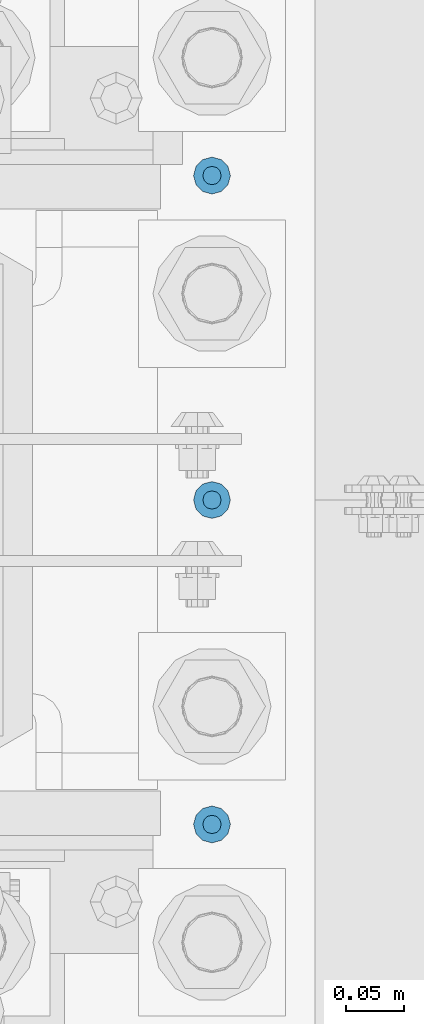
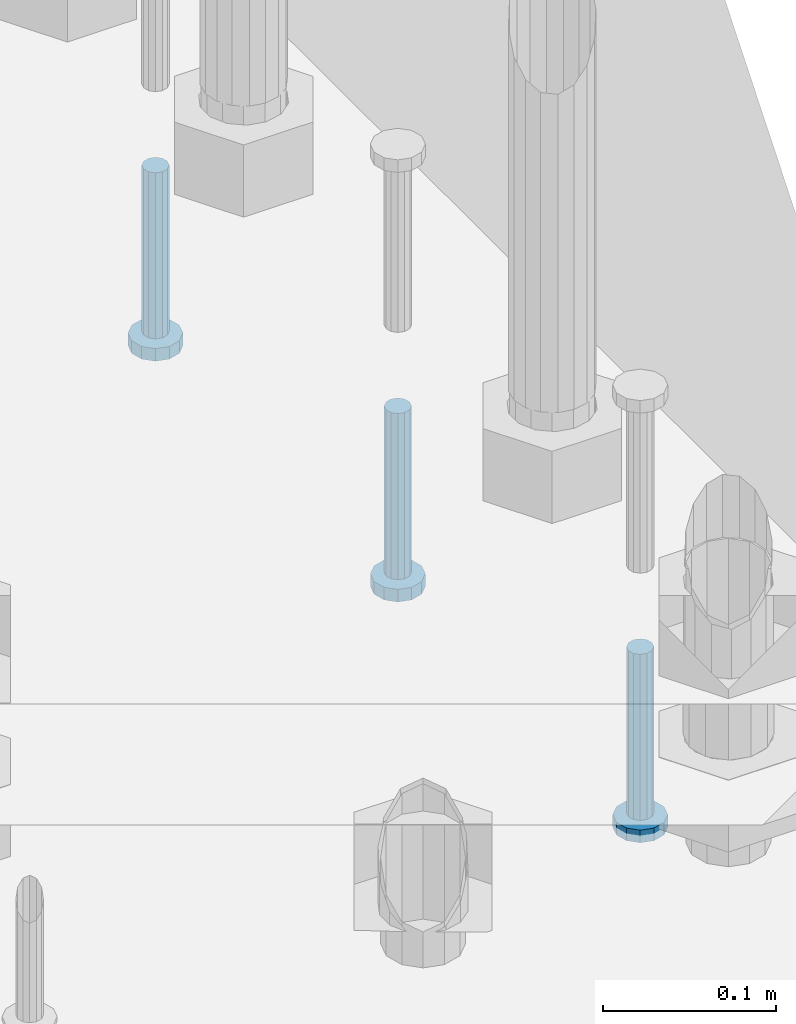
# One storey, part 1340 of 1876: 3 beams, 1 element without a shape of its own.
"""IFC2X3 building model written with IfcOpenShell, lengths in millimetres."""

from ifc_helpers import new_model, si_unit, frame, origin_with_axes, place, context, subcontext, project, spatial, faceted_brep, material, type_object, element, aggregate, save


model = new_model("IFC2X3")

# Units and contexts
model_context = context("Model", 3, precision=1e-05, world=origin_with_axes())
body_context = subcontext(model_context, "Body", "Model", "MODEL_VIEW")
ifc_project = project(units=[si_unit("LENGTHUNIT", "METRE", prefix="MILLI"), si_unit("AREAUNIT", "SQUARE_METRE"), si_unit("VOLUMEUNIT", "CUBIC_METRE"), si_unit("MASSUNIT", "GRAM", prefix="KILO"), si_unit("TIMEUNIT", "SECOND"), si_unit("PLANEANGLEUNIT", "RADIAN"), si_unit("SOLIDANGLEUNIT", "STERADIAN"), si_unit("THERMODYNAMICTEMPERATUREUNIT", "DEGREE_CELSIUS"), si_unit("LUMINOUSINTENSITYUNIT", "LUMEN")], contexts=[model_context])

# Site, building, storey
site_placement = place(None, origin_with_axes())
site = spatial("IfcSite", under=ifc_project, at=site_placement, CompositionType="ELEMENT")
building_placement = place(site_placement, origin_with_axes())
building = spatial("IfcBuilding", under=site, at=building_placement, Name="Undefined", CompositionType="ELEMENT")
storey_placement = place(building_placement, origin_with_axes())
storey = spatial("IfcBuildingStorey", under=building, at=storey_placement, Name="Undefined", CompositionType="ELEMENT", Elevation=0.0)

# Assembly, beams
assembly_placement = place(storey_placement, origin_with_axes())
assembly = element("IfcElementAssembly", 1, at=assembly_placement, inside=storey, Name="TEMPLATE", AssemblyPlace="NOTDEFINED", PredefinedType="RIGID_FRAME")
ifc_material = material(Name="STEEL/A108")
beam_type = type_object("IfcBeamType", Name="5/8-DIA_HEADED ANCHOR STUD", PredefinedType="NOTDEFINED")
beam_1_placement = place(assembly_placement, frame((7823.2, 7899.4, -793.75), z_axis=(1.0, 0.0, 0.0), x_axis=(0.0, 0.0, -1.0)))
beam_1 = element("IfcBeam", 2, at=beam_1_placement, type_object=beam_type, material=ifc_material, Name="HEADED ANCHOR STUD", ObjectType="5/8-DIA_HEADED ANCHOR STUD", context=body_context, shape_type="Brep", body=[
    faceted_brep([(0.0, -7.94000005722046, 0.0), (0.0, -6.86999988555908, -3.97000002861023), (116.84, -6.86999988555908, -3.97000002861023), (116.84, -7.94000005722046, 0.0), (0.0, -3.97000002861023, -6.86999988555908), (116.84, -3.97000002861023, -6.86999988555908), (0.0, 0.0, -7.94000005722046), (116.84, 0.0, -7.94000005722046), (0.0, 3.97000002861023, -6.86999988555908), (116.84, 3.97000002861023, -6.86999988555908), (0.0, 6.86999988555908, -3.97000002861023), (116.84, 6.86999988555908, -3.97000002861023), (0.0, 7.94000005722046, 0.0), (116.84, 7.94000005722046, 0.0), (0.0, 6.86999988555908, 3.97000002861023), (116.84, 6.86999988555908, 3.97000002861023), (0.0, 3.97000002861023, 6.86999988555908), (116.84, 3.97000002861023, 6.86999988555908), (0.0, 0.0, 7.94000005722046), (116.84, 0.0, 7.94000005722046), (0.0, -3.97000002861023, 6.86999988555908), (116.84, -3.97000002861023, 6.86999988555908), (0.0, -6.86999988555908, 3.97000002861023), (116.84, -6.86999988555908, 3.97000002861023), (118.11, -13.75, -7.94000005722046), (118.11, -15.8800001144409, 0.0), (118.11, -7.94000005722046, -13.75), (118.11, 0.0, -15.8800001144409), (118.11, 7.94000005722046, -13.75), (118.11, 13.75, -7.94000005722046), (118.11, 15.8800001144409, 0.0), (118.11, 13.75, 7.94000005722046), (118.11, 7.94000005722046, 13.75), (118.11, 0.0, 15.8800001144409), (118.11, -7.94000005722046, 13.75), (118.11, -13.75, 7.94000005722046), (127.0, -13.75, -7.94000005722046), (127.0, -15.8800001144409, 0.0), (127.0, -7.94000005722046, -13.75), (127.0, 0.0, -15.8800001144409), (127.0, 7.94000005722046, -13.75), (127.0, 13.75, -7.94000005722046), (127.0, 15.8800001144409, 0.0), (127.0, 13.75, 7.94000005722046), (127.0, 7.94000005722046, 13.75), (127.0, 0.0, 15.8800001144409), (127.0, -7.94000005722046, 13.75), (127.0, -13.75, 7.94000005722046)], [[[0, 1, 2, 3]], [[1, 4, 5, 2]], [[4, 6, 7, 5]], [[6, 8, 9, 7]], [[8, 10, 11, 9]], [[10, 12, 13, 11]], [[12, 14, 15, 13]], [[14, 16, 17, 15]], [[16, 18, 19, 17]], [[18, 20, 21, 19]], [[20, 22, 23, 21]], [[22, 0, 3, 23]], [[22, 20, 18, 16, 14, 12, 10, 8, 6, 4, 1, 0]], [[3, 2, 24, 25]], [[2, 5, 26, 24]], [[5, 7, 27, 26]], [[7, 9, 28, 27]], [[9, 11, 29, 28]], [[11, 13, 30, 29]], [[13, 15, 31, 30]], [[15, 17, 32, 31]], [[17, 19, 33, 32]], [[19, 21, 34, 33]], [[21, 23, 35, 34]], [[23, 3, 25, 35]], [[25, 24, 36, 37]], [[24, 26, 38, 36]], [[26, 27, 39, 38]], [[27, 28, 40, 39]], [[28, 29, 41, 40]], [[29, 30, 42, 41]], [[30, 31, 43, 42]], [[31, 32, 44, 43]], [[32, 33, 45, 44]], [[33, 34, 46, 45]], [[34, 35, 47, 46]], [[35, 25, 37, 47]], [[38, 39, 40, 41, 42, 43, 44, 45, 46, 47, 37, 36]]]),
])
beam_2_placement = place(assembly_placement, frame((7823.2, 7340.6, -793.75), z_axis=(1.0, 0.0, 0.0), x_axis=(0.0, 0.0, -1.0)))
beam_2 = element("IfcBeam", 3, at=beam_2_placement, type_object=beam_type, material=ifc_material, Name="HEADED ANCHOR STUD", ObjectType="5/8-DIA_HEADED ANCHOR STUD", context=body_context, shape_type="Brep", body=[
    faceted_brep([(0.0, -7.94000005722046, 0.0), (0.0, -6.86999988555908, -3.97000002861023), (116.84, -6.86999988555908, -3.97000002861023), (116.84, -7.94000005722046, 0.0), (0.0, -3.97000002861023, -6.86999988555908), (116.84, -3.97000002861023, -6.86999988555908), (0.0, 0.0, -7.94000005722046), (116.84, 0.0, -7.94000005722046), (0.0, 3.97000002861023, -6.86999988555908), (116.84, 3.97000002861023, -6.86999988555908), (0.0, 6.86999988555908, -3.97000002861023), (116.84, 6.86999988555908, -3.97000002861023), (0.0, 7.94000005722046, 0.0), (116.84, 7.94000005722046, 0.0), (0.0, 6.86999988555908, 3.97000002861023), (116.84, 6.86999988555908, 3.97000002861023), (0.0, 3.97000002861023, 6.86999988555908), (116.84, 3.97000002861023, 6.86999988555908), (0.0, 0.0, 7.94000005722046), (116.84, 0.0, 7.94000005722046), (0.0, -3.97000002861023, 6.86999988555908), (116.84, -3.97000002861023, 6.86999988555908), (0.0, -6.86999988555908, 3.97000002861023), (116.84, -6.86999988555908, 3.97000002861023), (118.11, -13.75, -7.94000005722046), (118.11, -15.8800001144409, 0.0), (118.11, -7.94000005722046, -13.75), (118.11, 0.0, -15.8800001144409), (118.11, 7.94000005722046, -13.75), (118.11, 13.75, -7.94000005722046), (118.11, 15.8800001144409, 0.0), (118.11, 13.75, 7.94000005722046), (118.11, 7.94000005722046, 13.75), (118.11, 0.0, 15.8800001144409), (118.11, -7.94000005722046, 13.75), (118.11, -13.75, 7.94000005722046), (127.0, -13.75, -7.94000005722046), (127.0, -15.8800001144409, 0.0), (127.0, -7.94000005722046, -13.75), (127.0, 0.0, -15.8800001144409), (127.0, 7.94000005722046, -13.75), (127.0, 13.75, -7.94000005722046), (127.0, 15.8800001144409, 0.0), (127.0, 13.75, 7.94000005722046), (127.0, 7.94000005722046, 13.75), (127.0, 0.0, 15.8800001144409), (127.0, -7.94000005722046, 13.75), (127.0, -13.75, 7.94000005722046)], [[[0, 1, 2, 3]], [[1, 4, 5, 2]], [[4, 6, 7, 5]], [[6, 8, 9, 7]], [[8, 10, 11, 9]], [[10, 12, 13, 11]], [[12, 14, 15, 13]], [[14, 16, 17, 15]], [[16, 18, 19, 17]], [[18, 20, 21, 19]], [[20, 22, 23, 21]], [[22, 0, 3, 23]], [[22, 20, 18, 16, 14, 12, 10, 8, 6, 4, 1, 0]], [[3, 2, 24, 25]], [[2, 5, 26, 24]], [[5, 7, 27, 26]], [[7, 9, 28, 27]], [[9, 11, 29, 28]], [[11, 13, 30, 29]], [[13, 15, 31, 30]], [[15, 17, 32, 31]], [[17, 19, 33, 32]], [[19, 21, 34, 33]], [[21, 23, 35, 34]], [[23, 3, 25, 35]], [[25, 24, 36, 37]], [[24, 26, 38, 36]], [[26, 27, 39, 38]], [[27, 28, 40, 39]], [[28, 29, 41, 40]], [[29, 30, 42, 41]], [[30, 31, 43, 42]], [[31, 32, 44, 43]], [[32, 33, 45, 44]], [[33, 34, 46, 45]], [[34, 35, 47, 46]], [[35, 25, 37, 47]], [[38, 39, 40, 41, 42, 43, 44, 45, 46, 47, 37, 36]]]),
])
beam_3_placement = place(assembly_placement, frame((7823.2, 7620.0, -793.75), z_axis=(1.0, 0.0, 0.0), x_axis=(0.0, 0.0, -1.0)))
beam_3 = element("IfcBeam", 4, at=beam_3_placement, type_object=beam_type, material=ifc_material, Name="HEADED ANCHOR STUD", ObjectType="5/8-DIA_HEADED ANCHOR STUD", context=body_context, shape_type="Brep", body=[
    faceted_brep([(0.0, -7.94000005722046, 0.0), (0.0, -6.86999988555908, -3.97000002861023), (116.84, -6.86999988555908, -3.97000002861023), (116.84, -7.94000005722046, 0.0), (0.0, -3.97000002861023, -6.86999988555908), (116.84, -3.97000002861023, -6.86999988555908), (0.0, 0.0, -7.94000005722046), (116.84, 0.0, -7.94000005722046), (0.0, 3.97000002861023, -6.86999988555908), (116.84, 3.97000002861023, -6.86999988555908), (0.0, 6.86999988555908, -3.97000002861023), (116.84, 6.86999988555908, -3.97000002861023), (0.0, 7.94000005722046, 0.0), (116.84, 7.94000005722046, 0.0), (0.0, 6.86999988555908, 3.97000002861023), (116.84, 6.86999988555908, 3.97000002861023), (0.0, 3.97000002861023, 6.86999988555908), (116.84, 3.97000002861023, 6.86999988555908), (0.0, 0.0, 7.94000005722046), (116.84, 0.0, 7.94000005722046), (0.0, -3.97000002861023, 6.86999988555908), (116.84, -3.97000002861023, 6.86999988555908), (0.0, -6.86999988555908, 3.97000002861023), (116.84, -6.86999988555908, 3.97000002861023), (118.11, -13.75, -7.94000005722046), (118.11, -15.8800001144409, 0.0), (118.11, -7.94000005722046, -13.75), (118.11, 0.0, -15.8800001144409), (118.11, 7.94000005722046, -13.75), (118.11, 13.75, -7.94000005722046), (118.11, 15.8800001144409, 0.0), (118.11, 13.75, 7.94000005722046), (118.11, 7.94000005722046, 13.75), (118.11, 0.0, 15.8800001144409), (118.11, -7.94000005722046, 13.75), (118.11, -13.75, 7.94000005722046), (127.0, -13.75, -7.94000005722046), (127.0, -15.8800001144409, 0.0), (127.0, -7.94000005722046, -13.75), (127.0, 0.0, -15.8800001144409), (127.0, 7.94000005722046, -13.75), (127.0, 13.75, -7.94000005722046), (127.0, 15.8800001144409, 0.0), (127.0, 13.75, 7.94000005722046), (127.0, 7.94000005722046, 13.75), (127.0, 0.0, 15.8800001144409), (127.0, -7.94000005722046, 13.75), (127.0, -13.75, 7.94000005722046)], [[[0, 1, 2, 3]], [[1, 4, 5, 2]], [[4, 6, 7, 5]], [[6, 8, 9, 7]], [[8, 10, 11, 9]], [[10, 12, 13, 11]], [[12, 14, 15, 13]], [[14, 16, 17, 15]], [[16, 18, 19, 17]], [[18, 20, 21, 19]], [[20, 22, 23, 21]], [[22, 0, 3, 23]], [[22, 20, 18, 16, 14, 12, 10, 8, 6, 4, 1, 0]], [[3, 2, 24, 25]], [[2, 5, 26, 24]], [[5, 7, 27, 26]], [[7, 9, 28, 27]], [[9, 11, 29, 28]], [[11, 13, 30, 29]], [[13, 15, 31, 30]], [[15, 17, 32, 31]], [[17, 19, 33, 32]], [[19, 21, 34, 33]], [[21, 23, 35, 34]], [[23, 3, 25, 35]], [[25, 24, 36, 37]], [[24, 26, 38, 36]], [[26, 27, 39, 38]], [[27, 28, 40, 39]], [[28, 29, 41, 40]], [[29, 30, 42, 41]], [[30, 31, 43, 42]], [[31, 32, 44, 43]], [[32, 33, 45, 44]], [[33, 34, 46, 45]], [[34, 35, 47, 46]], [[35, 25, 37, 47]], [[38, 39, 40, 41, 42, 43, 44, 45, 46, 47, 37, 36]]]),
])
aggregate(assembly, [beam_1, beam_2, beam_3])

save(model, "model.ifc")
